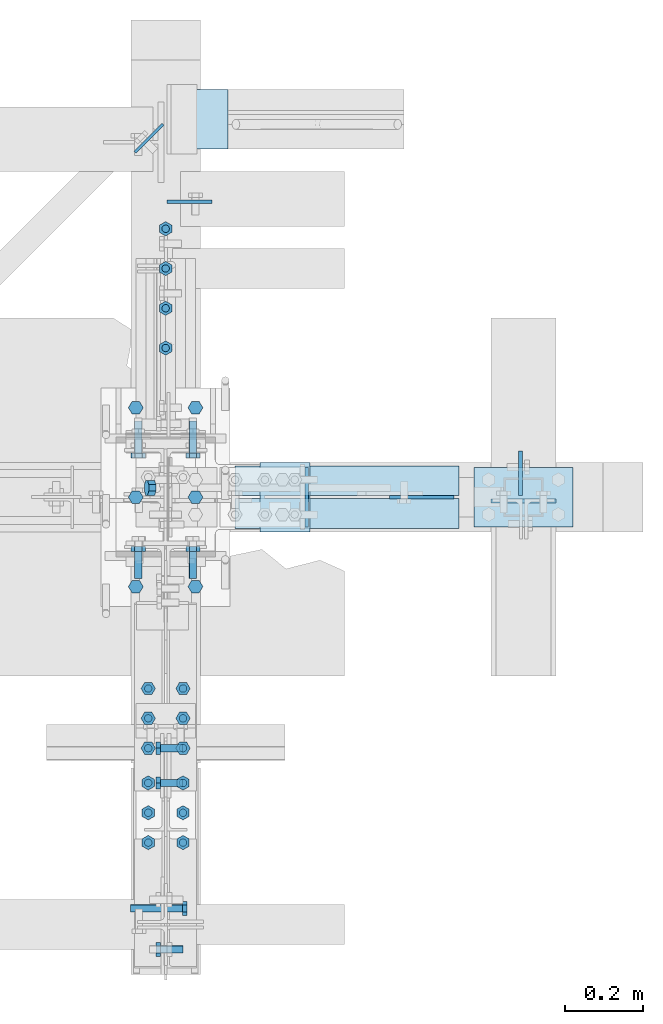
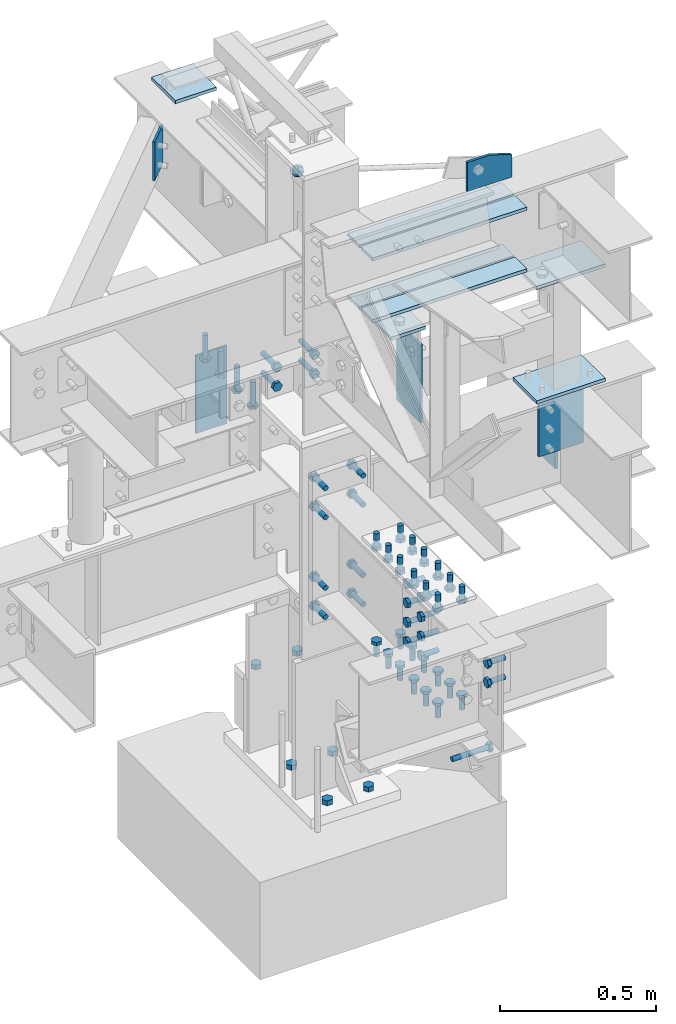
# Not in any storey, part 5 of 7: 51 mechanical fasteners, 21 plates, 16 elements without a shape of their own.
"""IFC2X3 building model written with IfcOpenShell, lengths in inches."""

from ifc_helpers import new_model, entity, si_unit, converted_unit, frame, origin_with_axes, origin_2d_with_axis, place, context, project, spatial, polyline, circle, outline, extrude, source, transform, mapped, material, type_object, type_shapes, element, aggregate, save


model = new_model("IFC2X3")

# Units and contexts
model_context = context("Model", 3, precision=1e-05, world=origin_with_axes())
ifc_project = project(units=[converted_unit("LENGTHUNIT", "INCH", entity("IfcLengthMeasure", 25.4), si_unit("LENGTHUNIT", "METRE", prefix="MILLI"), dimensions=[1, 0, 0, 0, 0, 0, 0]), si_unit("PLANEANGLEUNIT", "RADIAN"), si_unit("MASSUNIT", "GRAM", prefix="KILO"), si_unit("TIMEUNIT", "SECOND"), si_unit("AREAUNIT", "SQUARE_METRE"), si_unit("PRESSUREUNIT", "PASCAL"), si_unit("FORCEUNIT", "NEWTON"), si_unit("THERMODYNAMICTEMPERATUREUNIT", "DEGREE_CELSIUS")], contexts=[model_context])

# Site, building
site_placement = place(None, origin_with_axes())
site = spatial("IfcSite", under=ifc_project, at=site_placement, CompositionType="ELEMENT")
building_placement = place(site_placement, origin_with_axes())
building = spatial("IfcBuilding", under=site, at=building_placement, Name="Building", CompositionType="ELEMENT")

# Assembly, plate
assembly_1_placement = place(building_placement, frame((0.0, 38.0, 82.5), z_axis=(0.0, 0.0, -1.0), x_axis=(1.0, 0.0, 0.0)))
assembly_1 = element("IfcElementAssembly", 1, at=assembly_1_placement, inside=building, Name="M_41", PredefinedType="NOTDEFINED")
ifc_material = material()
plate_type_1 = type_object("IfcPlateType", Name="Plate (0-6x0-6)", PredefinedType="SHEET", material=ifc_material)
shared_shape_1 = source(origin_with_axes(), model_context, "Body", "SweptSolid", [
    extrude(outline(polyline([(0.0, -6.0), (-6.0, -6.0), (-6.0, 0.0), (0.0, 0.0), (0.0, -6.0)])), frame((-0.25, 0.0, 0.0), z_axis=(1.0, 0.0, 0.0), x_axis=(0.0, 1.0, 0.0)), (0.0, 0.0, 1.0), 0.5),
])
type_shapes(plate_type_1, [shared_shape_1])
plate_1_placement = place(assembly_1_placement, frame((6.25, -3.0, 2.24999999999999), z_axis=(0.0, -1.0, 0.0), x_axis=(0.0, 0.0, -1.0)))
plate_1 = element("IfcPlate", 2, at=plate_1_placement, type_object=plate_type_1, Name="p34", ObjectType="Member", context=model_context, shape_type="MappedRepresentation", body=[
    mapped(shared_shape_1, transform((0.0, 0.0, 0.0), scale=1.0)),
])
aggregate(assembly_1, [plate_1])

assembly_2_placement = place(building_placement, frame((23.9999999999998, 0.9375, 83.0), z_axis=(0.0, 1.0, 0.0), x_axis=(-0.954479957764932, 0.0, 0.29827505800024)))
assembly_2 = element("IfcElementAssembly", 3, at=assembly_2_placement, inside=building, Name="4-7", PredefinedType="NOTDEFINED")
plate_type_2 = type_object("IfcPlateType", Name="Plate (Complex)", PredefinedType="SHEET", material=ifc_material)
shared_shape_2 = source(origin_with_axes(), model_context, "Body", "SweptSolid", [
    extrude(outline(polyline([(0.0, -1.0625), (-0.4375, -1.5), (-1.0625, -1.5), (-1.5, -1.0625), (-1.5, -0.4375), (-1.0625, 0.0), (-0.4375, 0.0), (0.0, -0.4375), (0.0, -1.0625)])), frame((-0.375, 0.0, 0.0), z_axis=(1.0, 0.0, 0.0), x_axis=(0.0, 1.0, 0.0)), (0.0, 0.0, 1.0), 0.75),
])
type_shapes(plate_type_2, [shared_shape_2])
plate_2_placement = place(assembly_2_placement, frame((26.7744260805885, 0.749994139208951, 0.75), z_axis=(0.0, 0.0, 1.0), x_axis=(1.0, 0.0, 0.0)))
plate_2 = element("IfcPlate", 4, at=plate_2_placement, type_object=plate_type_2, Name="p16", ObjectType="Vertical brace", context=model_context, shape_type="MappedRepresentation", body=[
    mapped(shared_shape_2, transform((0.0, 0.0, 0.0), scale=1.0)),
])
aggregate(assembly_2, [plate_2])

assembly_3_placement = place(building_placement, frame((3.0, 0.0, -22.6679382324219), z_axis=(0.0, -1.0, 0.0), x_axis=(0.0, 0.0, 1.0)))
assembly_3 = element("IfcElementAssembly", 5, at=assembly_3_placement, inside=building, Name="M_36", PredefinedType="NOTDEFINED")
plate_type_3 = type_object("IfcPlateType", Name="Plate (Complex)", PredefinedType="SHEET", material=ifc_material)
shared_shape_3 = source(origin_with_axes(), model_context, "Body", "SweptSolid", [
    extrude(outline(polyline([(0.0, -1.125), (-0.625, -1.5), (-1.25, -1.125), (-1.25, -0.375), (-0.625, 0.0), (0.0, -0.375), (0.0, -1.125)])), frame((-0.375, 0.0, 0.0), z_axis=(1.0, 0.0, 0.0), x_axis=(0.0, 1.0, 0.0)), (0.0, 0.0, 1.0), 0.75),
])
type_shapes(plate_type_3, [shared_shape_3])
plate_3_placement = place(assembly_3_placement, frame((23.1679382324209, 0.75, -0.625), z_axis=(0.0, 1.0, 0.0), x_axis=(1.0, 0.0, 0.0)))
plate_3 = element("IfcPlate", 6, at=plate_3_placement, type_object=plate_type_3, Name="p55", ObjectType="Member", context=model_context, shape_type="MappedRepresentation", body=[
    mapped(shared_shape_3, transform((0.0, 0.0, 0.0), scale=1.0)),
])
aggregate(assembly_3, [plate_3])

assembly_4_placement = place(building_placement, frame((3.0, -9.0, -22.6679382324219), z_axis=(0.0, -1.0, 0.0), x_axis=(0.0, 0.0, 1.0)))
assembly_4 = element("IfcElementAssembly", 7, at=assembly_4_placement, inside=building, Name="M_36", PredefinedType="NOTDEFINED")
plate_4_placement = place(assembly_4_placement, frame((23.1679382324209, 0.75, -0.625), z_axis=(0.0, 1.0, 0.0), x_axis=(1.0, 0.0, 0.0)))
plate_4 = element("IfcPlate", 8, at=plate_4_placement, type_object=plate_type_3, Name="p55", ObjectType="Member", context=model_context, shape_type="MappedRepresentation", body=[
    mapped(shared_shape_3, transform((0.0, 0.0, 0.0), scale=1.0)),
])
aggregate(assembly_4, [plate_4])

assembly_5_placement = place(building_placement, frame((3.0, 9.0, -22.6679382324219), z_axis=(0.0, -1.0, 0.0), x_axis=(0.0, 0.0, 1.0)))
assembly_5 = element("IfcElementAssembly", 9, at=assembly_5_placement, inside=building, Name="M_48", PredefinedType="NOTDEFINED")
plate_5_placement = place(assembly_5_placement, frame((33.1679382324209, 0.75, -0.625), z_axis=(0.0, 1.0, 0.0), x_axis=(1.0, 0.0, 0.0)))
plate_5 = element("IfcPlate", 10, at=plate_5_placement, type_object=plate_type_3, Name="p55", ObjectType="Member", context=model_context, shape_type="MappedRepresentation", body=[
    mapped(shared_shape_3, transform((0.0, 0.0, 0.0), scale=1.0)),
])
aggregate(assembly_5, [plate_5])

assembly_6_placement = place(building_placement, frame((-3.0, 0.0, -22.6679382324219), z_axis=(0.0, -1.0, 0.0), x_axis=(0.0, 0.0, 1.0)))
assembly_6 = element("IfcElementAssembly", 11, at=assembly_6_placement, inside=building, Name="M_35", PredefinedType="NOTDEFINED")
plate_6_placement = place(assembly_6_placement, frame((23.1679382324209, 0.75, -0.625), z_axis=(0.0, 1.0, 0.0), x_axis=(1.0, 0.0, 0.0)))
plate_6 = element("IfcPlate", 12, at=plate_6_placement, type_object=plate_type_3, Name="p55", ObjectType="Member", context=model_context, shape_type="MappedRepresentation", body=[
    mapped(shared_shape_3, transform((0.0, 0.0, 0.0), scale=1.0)),
])
aggregate(assembly_6, [plate_6])

assembly_7_placement = place(building_placement, frame((-3.0, -9.0, -22.6679382324219), z_axis=(0.0, -1.0, 0.0), x_axis=(0.0, 0.0, 1.0)))
assembly_7 = element("IfcElementAssembly", 13, at=assembly_7_placement, inside=building, Name="M_35", PredefinedType="NOTDEFINED")
plate_7_placement = place(assembly_7_placement, frame((23.1679382324209, 0.75, -0.625), z_axis=(0.0, 1.0, 0.0), x_axis=(1.0, 0.0, 0.0)))
plate_7 = element("IfcPlate", 14, at=plate_7_placement, type_object=plate_type_3, Name="p55", ObjectType="Member", context=model_context, shape_type="MappedRepresentation", body=[
    mapped(shared_shape_3, transform((0.0, 0.0, 0.0), scale=1.0)),
])
aggregate(assembly_7, [plate_7])

assembly_8_placement = place(building_placement, frame((-3.0, 9.0, -22.6679382324219), z_axis=(0.0, -1.0, 0.0), x_axis=(0.0, 0.0, 1.0)))
assembly_8 = element("IfcElementAssembly", 15, at=assembly_8_placement, inside=building, Name="M_50", PredefinedType="NOTDEFINED")
plate_8_placement = place(assembly_8_placement, frame((33.1679382324209, 0.75, -0.625), z_axis=(0.0, 1.0, 0.0), x_axis=(1.0, 0.0, 0.0)))
plate_8 = element("IfcPlate", 16, at=plate_8_placement, type_object=plate_type_3, Name="p55", ObjectType="Member", context=model_context, shape_type="MappedRepresentation", body=[
    mapped(shared_shape_3, transform((0.0, 0.0, 0.0), scale=1.0)),
])
aggregate(assembly_8, [plate_8])

assembly_9_placement = place(building_placement, frame((0.0, 0.0, 46.0), z_axis=(0.0, 0.0, 1.0), x_axis=(0.0, 1.0, 0.0)))
assembly_9 = element("IfcElementAssembly", 17, at=assembly_9_placement, inside=building, Name="2-3", PredefinedType="NOTDEFINED")
plate_type_4 = type_object("IfcPlateType", Name="Plate (4 1/2x1-0)", PredefinedType="SHEET", material=ifc_material)
shared_shape_4 = source(origin_with_axes(), model_context, "Body", "SweptSolid", [
    extrude(outline(polyline([(0.0, -4.5), (-12.0, -4.5), (-12.0, 0.0), (0.0, 0.0), (0.0, -4.5)])), frame((-0.15625, 0.0, 0.0), z_axis=(1.0, 0.0, 0.0), x_axis=(0.0, 1.0, 0.0)), (0.0, 0.0, 1.0), 0.3125),
])
type_shapes(plate_type_4, [shared_shape_4])
plate_9_placement = place(assembly_9_placement, frame((29.71875, -0.14750000834465, -1.5), z_axis=(0.0, 1.0, 0.0), x_axis=(-1.0, 0.0, 0.0)))
plate_9 = element("IfcPlate", 18, at=plate_9_placement, type_object=plate_type_4, Name="p10", ObjectType="Beam", context=model_context, shape_type="MappedRepresentation", body=[
    mapped(shared_shape_4, transform((0.0, 0.0, 0.0), scale=1.0)),
])
aggregate(assembly_9, [plate_9])

assembly_10_placement = place(building_placement, frame((0.0, 0.0, 46.0), z_axis=(0.0, 0.0, 1.0), x_axis=(1.0, 0.0, 0.0)))
assembly_10 = element("IfcElementAssembly", 19, at=assembly_10_placement, inside=building, Name="2-5", PredefinedType="NOTDEFINED")
plate_type_5 = type_object("IfcPlateType", Name="Plate (4 1/2x0-9)", PredefinedType="SHEET", material=ifc_material)
shared_shape_5 = source(origin_with_axes(), model_context, "Body", "SweptSolid", [
    extrude(outline(polyline([(0.0, -4.5), (-9.0, -4.5), (-9.0, 0.0), (0.0, 0.0), (0.0, -4.5)])), frame((-0.1875, 0.0, 0.0), z_axis=(1.0, 0.0, 0.0), x_axis=(0.0, 1.0, 0.0)), (0.0, 0.0, 1.0), 0.375),
])
type_shapes(plate_type_5, [shared_shape_5])
plate_10_placement = place(assembly_10_placement, frame((35.6974999979138, 0.14750000834465, -4.5), z_axis=(0.0, -1.0, 0.0), x_axis=(1.0, 0.0, 0.0)))
plate_10 = element("IfcPlate", 20, at=plate_10_placement, type_object=plate_type_5, Name="p54", ObjectType="Beam", context=model_context, shape_type="MappedRepresentation", body=[
    mapped(shared_shape_5, transform((0.0, 0.0, 0.0), scale=1.0)),
])
aggregate(assembly_10, [plate_10])

assembly_11_placement = place(building_placement, frame((36.0, 0.0, 58.0), z_axis=(0.0, 0.0, 1.0), x_axis=(-1.0, 0.0, 0.0)))
assembly_11 = element("IfcElementAssembly", 21, at=assembly_11_placement, inside=building, Name="4-3", PredefinedType="NOTDEFINED")
plate_type_6 = type_object("IfcPlateType", Name="Plate (1-0x0-6)", PredefinedType="SHEET", material=ifc_material)
shared_shape_6 = source(origin_with_axes(), model_context, "Body", "SweptSolid", [
    extrude(outline(polyline([(0.0, -12.0), (-6.0, -12.0), (-6.0, 0.0), (0.0, 0.0), (0.0, -12.0)])), frame((-0.1875, 0.0, 0.0), z_axis=(1.0, 0.0, 0.0), x_axis=(0.0, 1.0, 0.0)), (0.0, 0.0, 1.0), 0.375),
])
type_shapes(plate_type_6, [shared_shape_6])
plate_11_placement = place(assembly_11_placement, frame((21.8125, 3.0, -9.0), z_axis=(0.0, 0.0, -1.0), x_axis=(-1.0, 0.0, 0.0)))
plate_11 = element("IfcPlate", 22, at=plate_11_placement, type_object=plate_type_6, Name="p1", ObjectType="Beam", context=model_context, shape_type="MappedRepresentation", body=[
    mapped(shared_shape_6, transform((0.0, 0.0, 0.0), scale=1.0)),
])
aggregate(assembly_11, [plate_11])

# Assembly, plates
assembly_12_placement = place(building_placement, frame((36.0, 0.0, 46.0), z_axis=(-1.0, 0.0, 0.0), x_axis=(0.0, 0.0, 1.0)))
assembly_12 = element("IfcElementAssembly", 23, at=assembly_12_placement, inside=building, Name="4-1", PredefinedType="NOTDEFINED")
plate_type_7 = type_object("IfcPlateType", Name="Plate (0-10x0-6)", PredefinedType="SHEET", material=ifc_material)
shared_shape_7 = source(origin_with_axes(), model_context, "Body", "SweptSolid", [
    extrude(outline(polyline([(3.0, -5.0), (-3.0, -5.0), (-3.0, 5.0), (3.0, 5.0), (3.0, -5.0)])), frame((-0.25, 0.0, 0.0), z_axis=(1.0, 0.0, 0.0), x_axis=(0.0, 1.0, 0.0)), (0.0, 0.0, 1.0), 0.5),
])
type_shapes(plate_type_7, [shared_shape_7])
plate_12_placement = place(assembly_12_placement, frame((0.25, 0.0, 0.0), z_axis=(0.0, 0.0, -1.0), x_axis=(1.0, 0.0, 0.0)))
plate_12 = element("IfcPlate", 24, at=plate_12_placement, type_object=plate_type_7, Name="p48", ObjectType="Column", context=model_context, shape_type="MappedRepresentation", body=[
    mapped(shared_shape_7, transform((0.0, 0.0, 0.0), scale=1.0)),
])
plate_13_placement = place(assembly_12_placement, frame((17.875, 0.0, 0.0), z_axis=(0.0, 0.0, -1.0), x_axis=(-1.0, 0.0, 0.0)))
plate_13 = element("IfcPlate", 25, at=plate_13_placement, type_object=plate_type_7, Name="p48", ObjectType="Column", context=model_context, shape_type="MappedRepresentation", body=[
    mapped(shared_shape_7, transform((0.0, 0.0, 0.0), scale=1.0)),
])
aggregate(assembly_12, [plate_12, plate_13])

# Assembly, plate
assembly_13_placement = place(building_placement, frame((36.0, 0.0, 46.0), z_axis=(0.0, 0.0, 1.0), x_axis=(0.0, -1.0, 0.0)))
assembly_13 = element("IfcElementAssembly", 26, at=assembly_13_placement, inside=building, Name="3-1", PredefinedType="NOTDEFINED")
plate_type_8 = type_object("IfcPlateType", Name="Plate (8 1/2x6 1/2)", PredefinedType="SHEET", material=ifc_material)
shared_shape_8 = source(origin_with_axes(), model_context, "Body", "SweptSolid", [
    extrude(outline(polyline([(3.25, -8.5), (-3.25, -8.5), (-3.25, 0.0), (3.25, 0.0), (3.25, -8.5)])), frame((-0.1875, 0.0, 0.0), z_axis=(1.0, 0.0, 0.0), x_axis=(0.0, 1.0, 0.0)), (0.0, 0.0, 1.0), 0.375),
])
type_shapes(plate_type_8, [shared_shape_8])
plate_14_placement = place(assembly_13_placement, frame((0.375, 0.0, -1.75), z_axis=(0.0, 0.0, 1.0), x_axis=(-1.0, 0.0, 0.0)))
plate_14 = element("IfcPlate", 27, at=plate_14_placement, type_object=plate_type_8, Name="p19", ObjectType="Beam", context=model_context, shape_type="MappedRepresentation", body=[
    mapped(shared_shape_8, transform((0.0, 0.0, 0.0), scale=1.0)),
])
aggregate(assembly_13, [plate_14])

assembly_14_placement = place(building_placement, frame((0.0, 0.0, 80.0), z_axis=(0.0, 0.0, 1.0), x_axis=(0.0, 1.0, 0.0)))
assembly_14 = element("IfcElementAssembly", 28, at=assembly_14_placement, inside=building, Name="2-6", PredefinedType="NOTDEFINED")
plate_type_9 = type_object("IfcPlateType", Name="Plate (0-4x0-6)", PredefinedType="SHEET", material=ifc_material)
shared_shape_9 = source(origin_with_axes(), model_context, "Body", "SweptSolid", [
    extrude(outline(polyline([(0.0, -4.0), (-6.0, -4.0), (-6.0, 0.0), (0.0, 0.0), (0.0, -4.0)])), frame((-0.15625, 0.0, 0.0), z_axis=(1.0, 0.0, 0.0), x_axis=(0.0, 1.0, 0.0)), (0.0, 0.0, 1.0), 0.3125),
])
type_shapes(plate_type_9, [shared_shape_9])
plate_15_placement = place(assembly_14_placement, frame((37.521045031785, 0.257985744020722, -4.5), z_axis=(0.707106796640858, -0.707106765732237, 0.0), x_axis=(0.707106765732237, 0.707106796640858, 0.0)))
plate_15 = element("IfcPlate", 29, at=plate_15_placement, type_object=plate_type_9, Name="p14", ObjectType="Beam", context=model_context, shape_type="MappedRepresentation", body=[
    mapped(shared_shape_9, transform((0.0, 0.0, 0.0), scale=1.0)),
])
aggregate(assembly_14, [plate_15])

# Assembly, plates
assembly_15_placement = place(building_placement, frame((0.0, 0.0, 80.0), z_axis=(0.0, 0.0, 1.0), x_axis=(1.0, 0.0, 0.0)))
assembly_15 = element("IfcElementAssembly", 30, at=assembly_15_placement, inside=building, Name="2-8", PredefinedType="NOTDEFINED")
plate_type_10 = type_object("IfcPlateType", Name="Plate (1-10 1/2x0-3)", PredefinedType="SHEET", material=ifc_material)
shared_shape_10 = source(origin_with_axes(), model_context, "Body", "SweptSolid", [
    extrude(outline(polyline([(0.0, -22.5), (-3.0, -22.5), (-3.0, 0.0), (0.0, 0.0), (0.0, -22.5)])), frame((-0.25, 0.0, 0.0), z_axis=(1.0, 0.0, 0.0), x_axis=(0.0, 1.0, 0.0)), (0.0, 0.0, 1.0), 0.5),
])
type_shapes(plate_type_10, [shared_shape_10])
plate_16_placement = place(assembly_15_placement, frame((29.5, 0.147500008344651, -12.75), z_axis=(1.0, 0.0, 0.0), x_axis=(0.0, 0.0, 1.0)))
plate_16 = element("IfcPlate", 31, at=plate_16_placement, type_object=plate_type_10, Name="p23", ObjectType="Beam", context=model_context, shape_type="MappedRepresentation", body=[
    mapped(shared_shape_10, transform((0.0, 0.0, 0.0), scale=1.0)),
])
plate_17_placement = place(assembly_15_placement, frame((7.0, -0.14750000834465, -12.75), z_axis=(-1.0, 0.0, 0.0), x_axis=(0.0, 0.0, 1.0)))
plate_17 = element("IfcPlate", 32, at=plate_17_placement, type_object=plate_type_10, Name="p23", ObjectType="Beam", context=model_context, shape_type="MappedRepresentation", body=[
    mapped(shared_shape_10, transform((0.0, 0.0, 0.0), scale=1.0)),
])
plate_18_placement = place(assembly_15_placement, frame((29.5, 0.147500008344651, -3.25), z_axis=(1.0, 0.0, 0.0), x_axis=(0.0, 0.0, 1.0)))
plate_18 = element("IfcPlate", 33, at=plate_18_placement, type_object=plate_type_10, Name="p23", ObjectType="Beam", context=model_context, shape_type="MappedRepresentation", body=[
    mapped(shared_shape_10, transform((0.0, 0.0, 0.0), scale=1.0)),
])
plate_19_placement = place(assembly_15_placement, frame((7.0, -0.14750000834465, -3.25), z_axis=(-1.0, 0.0, 0.0), x_axis=(0.0, 0.0, 1.0)))
plate_19 = element("IfcPlate", 34, at=plate_19_placement, type_object=plate_type_10, Name="p23", ObjectType="Beam", context=model_context, shape_type="MappedRepresentation", body=[
    mapped(shared_shape_10, transform((0.0, 0.0, 0.0), scale=1.0)),
])
plate_type_11 = type_object("IfcPlateType", Name="Plate (Complex)", PredefinedType="SHEET", material=ifc_material)
shared_shape_11 = source(origin_with_axes(), model_context, "Body", "SweptSolid", [
    extrude(outline(polyline([(0.0, -3.375), (-1.0, -6.5), (-4.5, -6.5), (-4.5, 0.0), (0.0, 0.0), (0.0, -3.375)])), frame((-0.1875, 0.0, 0.0), z_axis=(1.0, 0.0, 0.0), x_axis=(0.0, 1.0, 0.0)), (0.0, 0.0, 1.0), 0.375),
])
type_shapes(plate_type_11, [shared_shape_11])
plate_20_placement = place(assembly_15_placement, frame((22.5, 0.0, 4.5), z_axis=(-1.0, 0.0, 0.0), x_axis=(0.0, -1.0, 0.0)))
plate_20 = element("IfcPlate", 35, at=plate_20_placement, type_object=plate_type_11, Name="p49", ObjectType="Beam", context=model_context, shape_type="MappedRepresentation", body=[
    mapped(shared_shape_11, transform((0.0, 0.0, 0.0), scale=1.0)),
])
aggregate(assembly_15, [plate_16, plate_17, plate_18, plate_19, plate_20])

# Assembly, plate
assembly_16_placement = place(building_placement, frame((14.0, 0.0, 49.0), z_axis=(0.0, -1.0, 0.0), x_axis=(0.0, 0.0, 1.0)))
assembly_16 = element("IfcElementAssembly", 36, at=assembly_16_placement, inside=building, Name="4-4", PredefinedType="NOTDEFINED")
plate_type_12 = type_object("IfcPlateType", Name="Plate (0-5x0-7)", PredefinedType="SHEET", material=ifc_material)
shared_shape_12 = source(origin_with_axes(), model_context, "Body", "SweptSolid", [
    extrude(outline(polyline([(0.0, -5.0), (-7.0, -5.0), (-7.0, 0.0), (0.0, 0.0), (0.0, -5.0)])), frame((-0.25, 0.0, 0.0), z_axis=(1.0, 0.0, 0.0), x_axis=(0.0, 1.0, 0.0)), (0.0, 0.0, 1.0), 0.5),
])
type_shapes(plate_type_12, [shared_shape_12])
plate_21_placement = place(assembly_16_placement, frame((14.875, 4.5, -3.5), z_axis=(0.0, 1.0, 0.0), x_axis=(1.0, 0.0, 0.0)))
plate_21 = element("IfcPlate", 37, at=plate_21_placement, type_object=plate_type_12, Name="p8", ObjectType="Column", context=model_context, shape_type="MappedRepresentation", body=[
    mapped(shared_shape_12, transform((0.0, 0.0, 0.0), scale=1.0)),
])
aggregate(assembly_16, [plate_21])

# Mechanical fasteners
mechanical_fastener_type_1 = type_object("IfcMechanicalFastenerType")
shared_shape_13 = source(origin_with_axes(), model_context, "Body", "SweptSolid", [
    extrude(circle(Radius=0.375, at=origin_2d_with_axis()), frame((0.0, 0.0, 0.0), z_axis=(1.0, 0.0, 0.0), x_axis=(0.0, 1.0, 0.0)), (0.0, 0.0, 1.0), 3.5),
    extrude(outline(polyline([(-0.72, 0.0), (-0.36, 0.62352), (0.36, 0.62352), (0.72, 0.0), (0.36, -0.62352), (-0.36, -0.62352), (-0.72, 0.0)])), frame((0.0, 0.0, 0.0), z_axis=(1.0, 0.0, 0.0), x_axis=(0.0, 1.0, 0.0)), (0.0, 0.0, -1.0), 0.46987499999999993),
])
type_shapes(mechanical_fastener_type_1, [shared_shape_13])
placement_1 = place(assembly_9_placement, frame((19.0000038146973, 0.0, 0.0), z_axis=(0.0, -1.0, 0.0), x_axis=(0.0, 0.0, 1.0)))
mechanical_fastener_1_placement = place(placement_1, origin_with_axes())
element("IfcMechanicalFastener", 38, at=mechanical_fastener_1_placement, type_object=mechanical_fastener_type_1, ObjectType="Shear stud", NominalDiameter=0.75, NominalLength=3.5, context=model_context, shape_type="MappedRepresentation", body=[
    mapped(shared_shape_13, transform((0.0, 0.0, 0.0), scale=1.0)),
])
placement_2 = place(assembly_9_placement, frame((23.0000038146973, 0.0, 0.0), z_axis=(0.0, -1.0, 0.0), x_axis=(0.0, 0.0, 1.0)))
mechanical_fastener_2_placement = place(placement_2, origin_with_axes())
element("IfcMechanicalFastener", 39, at=mechanical_fastener_2_placement, type_object=mechanical_fastener_type_1, ObjectType="Shear stud", NominalDiameter=0.75, NominalLength=3.5, context=model_context, shape_type="MappedRepresentation", body=[
    mapped(shared_shape_13, transform((0.0, 0.0, 0.0), scale=1.0)),
])
placement_3 = place(assembly_9_placement, frame((27.0000038146973, 0.0, 0.0), z_axis=(0.0, -1.0, 0.0), x_axis=(0.0, 0.0, 1.0)))
mechanical_fastener_3_placement = place(placement_3, origin_with_axes())
element("IfcMechanicalFastener", 40, at=mechanical_fastener_3_placement, type_object=mechanical_fastener_type_1, ObjectType="Shear stud", NominalDiameter=0.75, NominalLength=3.5, context=model_context, shape_type="MappedRepresentation", body=[
    mapped(shared_shape_13, transform((0.0, 0.0, 0.0), scale=1.0)),
])
placement_4 = place(assembly_9_placement, frame((15.0000038146973, 0.0, 0.0), z_axis=(0.0, -1.0, 0.0), x_axis=(0.0, 0.0, 1.0)))
mechanical_fastener_4_placement = place(placement_4, origin_with_axes())
element("IfcMechanicalFastener", 41, at=mechanical_fastener_4_placement, type_object=mechanical_fastener_type_1, ObjectType="Shear stud", NominalDiameter=0.75, NominalLength=3.5, context=model_context, shape_type="MappedRepresentation", body=[
    mapped(shared_shape_13, transform((0.0, 0.0, 0.0), scale=1.0)),
])
mechanical_fastener_type_2 = type_object("IfcMechanicalFastenerType")
shared_shape_14 = source(origin_with_axes(), model_context, "Body", "SweptSolid", [
    extrude(circle(Radius=0.375, at=origin_2d_with_axis()), frame((0.0, 0.0, 0.0), z_axis=(1.0, 0.0, 0.0), x_axis=(0.0, 1.0, 0.0)), (0.0, 0.0, 1.0), 2.25),
    extrude(outline(polyline([(-0.72, 0.0), (-0.36, 0.62352), (0.36, 0.62352), (0.72, 0.0), (0.36, -0.62352), (-0.36, -0.62352), (-0.72, 0.0)])), frame((0.0, 0.0, 0.0), z_axis=(1.0, 0.0, 0.0), x_axis=(0.0, 1.0, 0.0)), (0.0, 0.0, -1.0), 0.46987499999999993),
])
type_shapes(mechanical_fastener_type_2, [shared_shape_14])
placement_5 = place(building_placement, frame((0.0, -27.0, 46.0), z_axis=(0.0, 0.0, 1.0), x_axis=(0.0, -1.0, 0.0)))
placement_6 = place(placement_5, frame((1.75, -0.52250000834465, -3.0), z_axis=(1.0, 0.0, 0.0), x_axis=(0.0, 1.0, 0.0)))
for number, where, z_axis, x_axis in (
    (42, (0.0, 0.0, 0.0), (0.0, 0.0, 1.0), (1.0, 0.0, 0.0)),
    (43, (0.0, -9.0, 0.0), (0.0, 0.0, 1.0), (1.0, 0.0, 0.0)),
    (44, (0.0, -6.0, 0.0), (0.0, 0.0, 1.0), (1.0, 0.0, 0.0)),
    (45, (0.0, -3.0, 0.0), (0.0, 0.0, 1.0), (1.0, 0.0, 0.0)),
):
    element("IfcMechanicalFastener", number, at=place(placement_6, frame(where, z_axis=z_axis, x_axis=x_axis)), type_object=mechanical_fastener_type_2, ObjectType="Bolt", NominalDiameter=0.75, NominalLength=2.25, context=model_context, shape_type="MappedRepresentation", body=[
        mapped(shared_shape_14, transform((0.0, 0.0, 0.0), scale=1.0)),
    ])
placement_7 = place(building_placement, frame((0.0, -43.0, 46.0), z_axis=(0.0, 0.0, 1.0), x_axis=(1.0, 0.0, 0.0)))
placement_8 = place(placement_7, frame((-0.5, -2.5, -6.0), z_axis=(0.0, 0.0, 1.0), x_axis=(1.0, 0.0, 0.0)))
for number, where, z_axis, x_axis in (
    (46, (0.0, 0.0, 3.0), (0.0, 0.0, 1.0), (1.0, 0.0, 0.0)),
    (47, (0.0, 0.0, 0.0), (0.0, 0.0, 1.0), (1.0, 0.0, 0.0)),
):
    element("IfcMechanicalFastener", number, at=place(placement_8, frame(where, z_axis=z_axis, x_axis=x_axis)), type_object=mechanical_fastener_type_2, ObjectType="Bolt", NominalDiameter=0.75, NominalLength=2.25, context=model_context, shape_type="MappedRepresentation", body=[
        mapped(shared_shape_14, transform((0.0, 0.0, 0.0), scale=1.0)),
    ])
mechanical_fastener_type_3 = type_object("IfcMechanicalFastenerType")
shared_shape_15 = source(origin_with_axes(), model_context, "Body", "SweptSolid", [
    extrude(circle(Radius=0.375, at=origin_2d_with_axis()), frame((0.0, 0.0, 0.0), z_axis=(1.0, 0.0, 0.0), x_axis=(0.0, 1.0, 0.0)), (0.0, 0.0, 1.0), 3.25),
    extrude(outline(polyline([(-0.72, 0.0), (-0.36, 0.62352), (0.36, 0.62352), (0.72, 0.0), (0.36, -0.62352), (-0.36, -0.62352), (-0.72, 0.0)])), frame((0.0, 0.0, 0.0), z_axis=(1.0, 0.0, 0.0), x_axis=(0.0, 1.0, 0.0)), (0.0, 0.0, -1.0), 0.46987499999999993),
])
type_shapes(mechanical_fastener_type_3, [shared_shape_15])
placement_9 = place(building_placement, frame((0.0, 0.0, 54.5), z_axis=(0.0, -1.0, 0.0), x_axis=(0.0, 0.0, 1.0)))
placement_10 = place(placement_9, frame((1.75, 2.75, -4.42999982833862), z_axis=(1.0, 0.0, 0.0), x_axis=(0.0, 0.0, -1.0)))
for number, where, z_axis, x_axis in (
    (48, (0.0, 0.0, 3.0), (0.0, 0.0, 1.0), (1.0, 0.0, 0.0)),
    (49, (0.0, 0.0, 0.0), (0.0, 0.0, 1.0), (1.0, 0.0, 0.0)),
    (50, (0.0, -5.5, 3.0), (0.0, 0.0, 1.0), (1.0, 0.0, 0.0)),
    (51, (0.0, -5.5, 0.0), (0.0, 0.0, 1.0), (1.0, 0.0, 0.0)),
):
    element("IfcMechanicalFastener", number, at=place(placement_10, frame(where, z_axis=z_axis, x_axis=x_axis)), type_object=mechanical_fastener_type_3, ObjectType="Bolt", NominalDiameter=0.75, NominalLength=3.25, context=model_context, shape_type="MappedRepresentation", body=[
        mapped(shared_shape_15, transform((0.0, 0.0, 0.0), scale=1.0)),
    ])
mechanical_fastener_type_4 = type_object("IfcMechanicalFastenerType")
shared_shape_16 = source(origin_with_axes(), model_context, "Body", "SweptSolid", [
    extrude(circle(Radius=0.375, at=origin_2d_with_axis()), frame((0.0, 0.0, 0.0), z_axis=(1.0, 0.0, 0.0), x_axis=(0.0, 1.0, 0.0)), (0.0, 0.0, 1.0), 2.0),
    extrude(outline(polyline([(-0.72, 0.0), (-0.36, 0.62352), (0.36, 0.62352), (0.72, 0.0), (0.36, -0.62352), (-0.36, -0.62352), (-0.72, 0.0)])), frame((0.0, 0.0, 0.0), z_axis=(1.0, 0.0, 0.0), x_axis=(0.0, 1.0, 0.0)), (0.0, 0.0, -1.0), 0.46987499999999993),
])
type_shapes(mechanical_fastener_type_4, [shared_shape_16])
placement_11 = place(building_placement, frame((0.0, 0.0, 46.0), z_axis=(0.0, 0.0, 1.0), x_axis=(0.0, -1.0, 0.0)))
placement_12 = place(placement_11, frame((25.25, -1.75, -0.430000007152557), z_axis=(1.0, 0.0, 0.0), x_axis=(0.0, 0.0, 1.0)))
for number, where, z_axis, x_axis in (
    (52, (0.0, 0.0, 0.0), (0.0, 0.0, 1.0), (1.0, 0.0, 0.0)),
    (53, (0.0, 0.0, -6.0), (0.0, 0.0, 1.0), (1.0, 0.0, 0.0)),
    (54, (0.0, 0.0, -3.0), (0.0, 0.0, 1.0), (1.0, 0.0, 0.0)),
    (55, (0.0, -3.5, 0.0), (0.0, 0.0, 1.0), (1.0, 0.0, 0.0)),
    (56, (0.0, -3.5, -6.0), (0.0, 0.0, 1.0), (1.0, 0.0, 0.0)),
    (57, (0.0, -3.5, -3.0), (0.0, 0.0, 1.0), (1.0, 0.0, 0.0)),
):
    element("IfcMechanicalFastener", number, at=place(placement_12, frame(where, z_axis=z_axis, x_axis=x_axis)), type_object=mechanical_fastener_type_4, ObjectType="Bolt", NominalDiameter=0.75, NominalLength=2.0, context=model_context, shape_type="MappedRepresentation", body=[
        mapped(shared_shape_16, transform((0.0, 0.0, 0.0), scale=1.0)),
    ])
placement_13 = place(placement_11, frame((25.25, -1.75, -15.4299993515015), z_axis=(1.0, 0.0, 0.0), x_axis=(0.0, 0.0, -1.0)))
for number, where, z_axis, x_axis in (
    (58, (0.0, 3.5, 0.0), (0.0, 0.0, 1.0), (1.0, 0.0, 0.0)),
    (59, (0.0, 3.5, -6.0), (0.0, 0.0, 1.0), (1.0, 0.0, 0.0)),
    (60, (0.0, 3.5, -3.0), (0.0, 0.0, 1.0), (1.0, 0.0, 0.0)),
    (61, (0.0, 0.0, 0.0), (0.0, 0.0, 1.0), (1.0, 0.0, 0.0)),
    (62, (0.0, 0.0, -6.0), (0.0, 0.0, 1.0), (1.0, 0.0, 0.0)),
    (63, (0.0, 0.0, -3.0), (0.0, 0.0, 1.0), (1.0, 0.0, 0.0)),
):
    element("IfcMechanicalFastener", number, at=place(placement_13, frame(where, z_axis=z_axis, x_axis=x_axis)), type_object=mechanical_fastener_type_4, ObjectType="Bolt", NominalDiameter=0.75, NominalLength=2.0, context=model_context, shape_type="MappedRepresentation", body=[
        mapped(shared_shape_16, transform((0.0, 0.0, 0.0), scale=1.0)),
    ])
mechanical_fastener_type_5 = type_object("IfcMechanicalFastenerType")
shared_shape_17 = source(origin_with_axes(), model_context, "Body", "SweptSolid", [
    extrude(circle(Radius=0.375, at=origin_2d_with_axis()), frame((0.0, 0.0, 0.0), z_axis=(1.0, 0.0, 0.0), x_axis=(0.0, 1.0, 0.0)), (0.0, 0.0, 1.0), 2.0),
    extrude(outline(polyline([(-0.72, 0.0), (-0.36, 0.62352), (0.36, 0.62352), (0.72, 0.0), (0.36, -0.62352), (-0.36, -0.62352), (-0.72, 0.0)])), frame((0.0, 0.0, 0.0), z_axis=(1.0, 0.0, 0.0), x_axis=(0.0, 1.0, 0.0)), (0.0, 0.0, -1.0), 0.46987499999999993),
])
type_shapes(mechanical_fastener_type_5, [shared_shape_17])
placement_14 = place(placement_11, frame((28.75, -1.75, -0.430000007152557), z_axis=(0.0, 1.0, 0.0), x_axis=(0.0, 0.0, 1.0)))
for number, where, z_axis, x_axis in (
    (64, (0.0, 6.0, 3.5), (0.0, 0.0, 1.0), (1.0, 0.0, 0.0)),
    (65, (0.0, 6.0, 0.0), (0.0, 0.0, 1.0), (1.0, 0.0, 0.0)),
    (66, (0.0, 3.0, 3.5), (0.0, 0.0, 1.0), (1.0, 0.0, 0.0)),
    (67, (0.0, 3.0, 0.0), (0.0, 0.0, 1.0), (1.0, 0.0, 0.0)),
    (68, (0.0, 0.0, 3.5), (0.0, 0.0, 1.0), (1.0, 0.0, 0.0)),
    (69, (0.0, 0.0, 0.0), (0.0, 0.0, 1.0), (1.0, 0.0, 0.0)),
):
    element("IfcMechanicalFastener", number, at=place(placement_14, frame(where, z_axis=z_axis, x_axis=x_axis)), type_object=mechanical_fastener_type_5, ObjectType="Bolt", NominalDiameter=0.75, NominalLength=2.0, context=model_context, shape_type="MappedRepresentation", body=[
        mapped(shared_shape_17, transform((0.0, 0.0, 0.0), scale=1.0)),
    ])
placement_15 = place(placement_11, frame((28.75, -1.75, -15.4299993515015), z_axis=(0.0, 1.0, 0.0), x_axis=(0.0, 0.0, -1.0)))
for number, where, z_axis, x_axis in (
    (70, (0.0, 0.0, 3.5), (0.0, 0.0, 1.0), (1.0, 0.0, 0.0)),
    (71, (0.0, 0.0, 0.0), (0.0, 0.0, 1.0), (1.0, 0.0, 0.0)),
    (72, (0.0, -6.0, 3.5), (0.0, 0.0, 1.0), (1.0, 0.0, 0.0)),
    (73, (0.0, -6.0, 0.0), (0.0, 0.0, 1.0), (1.0, 0.0, 0.0)),
    (74, (0.0, -3.0, 3.5), (0.0, 0.0, 1.0), (1.0, 0.0, 0.0)),
    (75, (0.0, -3.0, 0.0), (0.0, 0.0, 1.0), (1.0, 0.0, 0.0)),
):
    element("IfcMechanicalFastener", number, at=place(placement_15, frame(where, z_axis=z_axis, x_axis=x_axis)), type_object=mechanical_fastener_type_5, ObjectType="Bolt", NominalDiameter=0.75, NominalLength=2.0, context=model_context, shape_type="MappedRepresentation", body=[
        mapped(shared_shape_17, transform((0.0, 0.0, 0.0), scale=1.0)),
    ])
mechanical_fastener_type_6 = type_object("IfcMechanicalFastenerType")
shared_shape_18 = source(origin_with_axes(), model_context, "Body", "SweptSolid", [
    extrude(circle(Radius=0.375, at=origin_2d_with_axis()), frame((0.0, 0.0, 0.0), z_axis=(1.0, 0.0, 0.0), x_axis=(0.0, 1.0, 0.0)), (0.0, 0.0, 1.0), 2.75),
    extrude(outline(polyline([(-0.72, 0.0), (-0.36, 0.62352), (0.36, 0.62352), (0.72, 0.0), (0.36, -0.62352), (-0.36, -0.62352), (-0.72, 0.0)])), frame((0.0, 0.0, 0.0), z_axis=(1.0, 0.0, 0.0), x_axis=(0.0, 1.0, 0.0)), (0.0, 0.0, -1.0), 0.46987499999999993),
])
type_shapes(mechanical_fastener_type_6, [shared_shape_18])
placement_16 = place(placement_11, frame((5.45500040054321, -2.75, 2.0), z_axis=(0.0, 0.0, -1.0), x_axis=(1.0, 0.0, 0.0)))
for number, where, z_axis, x_axis in (
    (76, (0.0, 0.0, 4.5), (0.0, 0.0, 1.0), (1.0, 0.0, 0.0)),
    (77, (0.0, 0.0, 19.8599996566772), (0.0, 0.0, 1.0), (1.0, 0.0, 0.0)),
    (78, (0.0, 0.0, 15.3599996566772), (0.0, 0.0, 1.0), (1.0, 0.0, 0.0)),
    (79, (0.0, 0.0, 0.0), (0.0, 0.0, 1.0), (1.0, 0.0, 0.0)),
    (80, (0.0, -5.5, 4.5), (0.0, 0.0, 1.0), (1.0, 0.0, 0.0)),
    (81, (0.0, -5.5, 19.8599996566772), (0.0, 0.0, 1.0), (1.0, 0.0, 0.0)),
    (82, (0.0, -5.5, 15.3599996566772), (0.0, 0.0, 1.0), (1.0, 0.0, 0.0)),
    (83, (0.0, -5.5, 0.0), (0.0, 0.0, 1.0), (1.0, 0.0, 0.0)),
):
    element("IfcMechanicalFastener", number, at=place(placement_16, frame(where, z_axis=z_axis, x_axis=x_axis)), type_object=mechanical_fastener_type_6, ObjectType="Bolt", NominalDiameter=0.75, NominalLength=2.75, context=model_context, shape_type="MappedRepresentation", body=[
        mapped(shared_shape_18, transform((0.0, 0.0, 0.0), scale=1.0)),
    ])
mechanical_fastener_type_7 = type_object("IfcMechanicalFastenerType")
shared_shape_19 = source(origin_with_axes(), model_context, "Body", "SweptSolid", [
    extrude(circle(Radius=0.375, at=origin_2d_with_axis()), frame((0.0, 0.0, 0.0), z_axis=(1.0, 0.0, 0.0), x_axis=(0.0, 1.0, 0.0)), (0.0, 0.0, 1.0), 2.25),
    extrude(outline(polyline([(-0.72, 0.0), (-0.36, 0.62352), (0.36, 0.62352), (0.72, 0.0), (0.36, -0.62352), (-0.36, -0.62352), (-0.72, 0.0)])), frame((0.0, 0.0, 0.0), z_axis=(1.0, 0.0, 0.0), x_axis=(0.0, 1.0, 0.0)), (0.0, 0.0, -1.0), 0.46987499999999993),
])
type_shapes(mechanical_fastener_type_7, [shared_shape_19])
placement_17 = place(placement_11, frame((25.25, -0.52250000834465, -3.0), z_axis=(1.0, 0.0, 0.0), x_axis=(0.0, 1.0, 0.0)))
for number, where, z_axis, x_axis in (
    (84, (0.0, 0.0, 0.0), (0.0, 0.0, 1.0), (1.0, 0.0, 0.0)),
    (85, (0.0, -9.0, 0.0), (0.0, 0.0, 1.0), (1.0, 0.0, 0.0)),
    (86, (0.0, -6.0, 0.0), (0.0, 0.0, 1.0), (1.0, 0.0, 0.0)),
    (87, (0.0, -3.0, 0.0), (0.0, 0.0, 1.0), (1.0, 0.0, 0.0)),
):
    element("IfcMechanicalFastener", number, at=place(placement_17, frame(where, z_axis=z_axis, x_axis=x_axis)), type_object=mechanical_fastener_type_7, ObjectType="Bolt", NominalDiameter=0.75, NominalLength=2.25, context=model_context, shape_type="MappedRepresentation", body=[
        mapped(shared_shape_19, transform((0.0, 0.0, 0.0), scale=1.0)),
    ])
mechanical_fastener_type_8 = type_object("IfcMechanicalFastenerType")
shared_shape_20 = source(origin_with_axes(), model_context, "Body", "SweptSolid", [
    extrude(circle(Radius=0.375, at=origin_2d_with_axis()), frame((0.0, 0.0, 0.0), z_axis=(1.0, 0.0, 0.0), x_axis=(0.0, 1.0, 0.0)), (0.0, 0.0, 1.0), 5.25),
    extrude(outline(polyline([(-0.72, 0.0), (-0.36, 0.62352), (0.36, 0.62352), (0.72, 0.0), (0.36, -0.62352), (-0.36, -0.62352), (-0.72, 0.0)])), frame((0.0, 0.0, 0.0), z_axis=(1.0, 0.0, 0.0), x_axis=(0.0, 1.0, 0.0)), (0.0, 0.0, -1.0), 0.46987499999999993),
])
type_shapes(mechanical_fastener_type_8, [shared_shape_20])
placement_18 = place(building_placement, frame((-0.302501678466797, -6.35499954223631, 7.97817420959473), z_axis=(0.0, 0.470283939984076, 0.882515164624979), x_axis=(0.0, -0.882515164624978, 0.470283939984076)))
placement_19 = place(placement_18, frame((39.6820381421194, 2.0, -7.25433721981972e-08), z_axis=(-0.470283939984076, 0.0, -0.882515164624979), x_axis=(0.0, -1.0, 0.0)))
mechanical_fastener_5_placement = place(placement_19, origin_with_axes())
element("IfcMechanicalFastener", 88, at=mechanical_fastener_5_placement, type_object=mechanical_fastener_type_8, ObjectType="Bolt", NominalDiameter=0.75, NominalLength=5.25, context=model_context, shape_type="MappedRepresentation", body=[
    mapped(shared_shape_20, transform((0.0, 0.0, 0.0), scale=1.0)),
])

save(model, "model.ifc")
